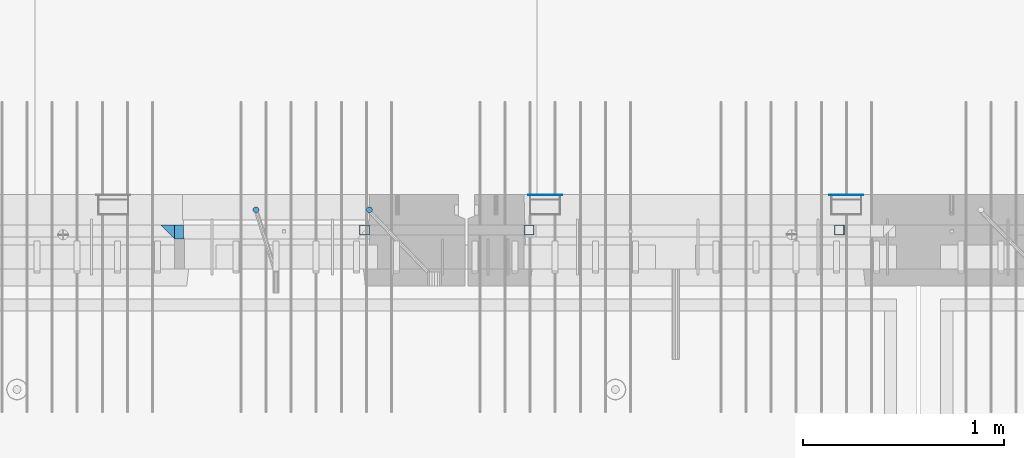
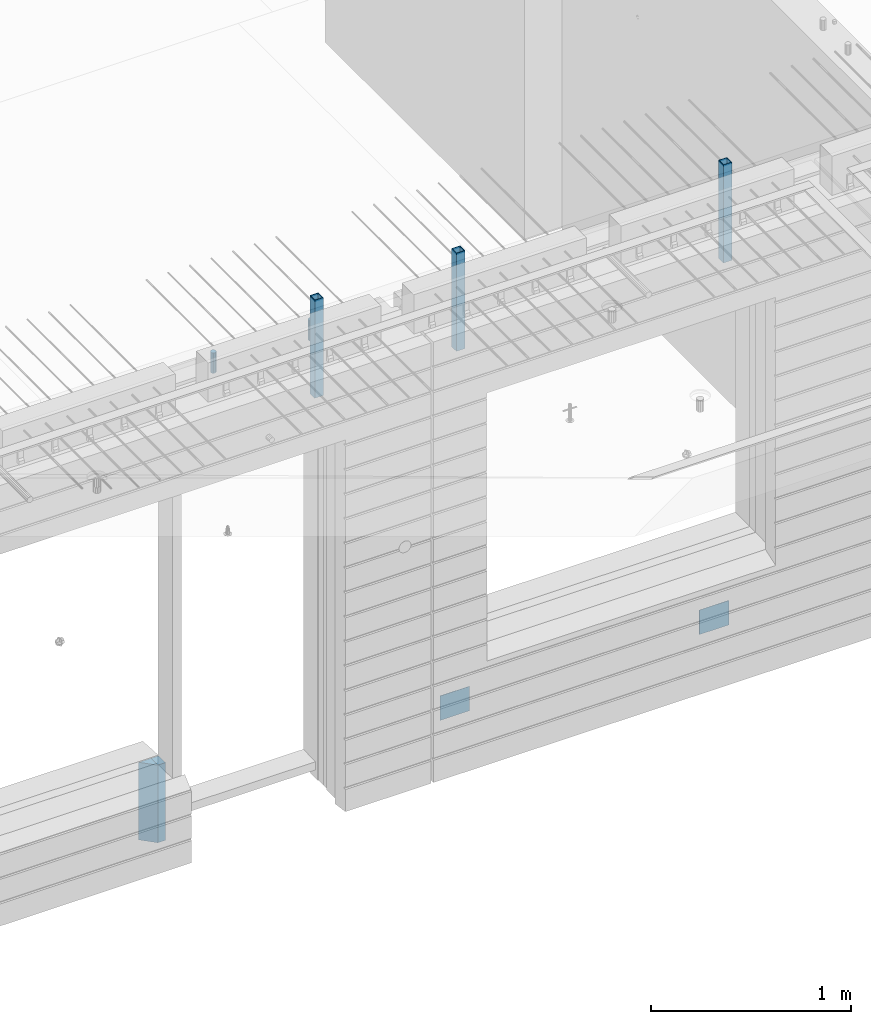
# One storey, part 17 of 349: 9 columns, 7 elements without a shape of their own.
"""IFC2X3 building model written with IfcOpenShell, lengths in millimetres."""

from ifc_helpers import new_model, si_unit, frame, origin_with_axes, place, context, subcontext, project, spatial, faceted_brep, material, type_object, element, aggregate, save


model = new_model("IFC2X3")

# Units and contexts
model_context = context("Model", 3, precision=1e-05, world=origin_with_axes())
body_context = subcontext(model_context, "Body", "Model", "MODEL_VIEW")
ifc_project = project(units=[si_unit("LENGTHUNIT", "METRE", prefix="MILLI"), si_unit("AREAUNIT", "SQUARE_METRE"), si_unit("VOLUMEUNIT", "CUBIC_METRE"), si_unit("MASSUNIT", "GRAM", prefix="KILO"), si_unit("TIMEUNIT", "SECOND"), si_unit("PLANEANGLEUNIT", "RADIAN"), si_unit("SOLIDANGLEUNIT", "STERADIAN"), si_unit("THERMODYNAMICTEMPERATUREUNIT", "DEGREE_CELSIUS"), si_unit("LUMINOUSINTENSITYUNIT", "LUMEN")], contexts=[model_context])

# Site, building, storey
site_placement = place(None, origin_with_axes())
site = spatial("IfcSite", under=ifc_project, at=site_placement, CompositionType="ELEMENT")
building_placement = place(site_placement, origin_with_axes())
building = spatial("IfcBuilding", under=site, at=building_placement, CompositionType="ELEMENT")
storey_placement = place(building_placement, origin_with_axes())
storey = spatial("IfcBuildingStorey", under=building, at=storey_placement, Name="4", CompositionType="ELEMENT", Elevation=0.0)

# Assembly, columns
assembly_1_placement = place(storey_placement, origin_with_axes())
assembly_1 = element("IfcElementAssembly", 1, at=assembly_1_placement, inside=storey, AssemblyPlace="NOTDEFINED", PredefinedType="REINFORCEMENT_UNIT")
ifc_material_1 = material(Name="CONCRETE/C35/45")
column_type_1 = type_object("IfcColumnType", PredefinedType="NOTDEFINED")
column_1_placement = place(assembly_1_placement, frame((24069.9998642727, 7815.0, 90755.0), z_axis=(1.0, 0.0, 0.0), x_axis=(0.0, 0.0, 1.0)))
column_1 = element("IfcColumn", 2, at=column_1_placement, type_object=column_type_1, material=ifc_material_1, Name="SK", context=body_context, shape_type="Brep", body=[
    faceted_brep([(0.0, -35.0, 35.0), (0.0, 35.0, 35.0), (0.0, -35.0, -35.0), (475.0, -35.0, 35.0), (475.0, -35.0, -35.0), (475.0, 35.0, 35.0)], [[[0, 1, 2]], [[3, 0, 2, 4]], [[3, 4, 5]], [[2, 1, 5, 4]], [[0, 3, 5, 1]]]),
])
column_type_2 = type_object("IfcColumnType", PredefinedType="NOTDEFINED")
column_2_placement = place(assembly_1_placement, frame((24129.9998642727, 7815.0, 90755.0), z_axis=(1.0, 0.0, 0.0), x_axis=(0.0, 0.0, 1.0)))
column_2 = element("IfcColumn", 3, at=column_2_placement, type_object=column_type_2, material=ifc_material_1, Name="SK", context=body_context, shape_type="Brep", body=[
    faceted_brep([(0.0, -35.0, -25.0), (0.0, 35.0, -25.0), (475.0, 35.0, -25.0), (475.0, -35.0, -25.0), (0.0, -35.0, 18.8457723764259), (0.0, 35.0, 20.640644171297), (475.0, 35.0, 20.640644171297), (475.0, -35.0, 18.8457723764259)], [[[0, 1, 2, 3]], [[1, 0, 4, 5]], [[2, 1, 5, 6]], [[3, 2, 6, 7]], [[0, 3, 7, 4]], [[6, 5, 4, 7]]]),
])
ifc_material_2 = material()
column_type_3 = type_object("IfcColumnType", Name="D30", PredefinedType="NOTDEFINED")
column_3_placement = place(assembly_1_placement, frame((24510.0000000048, 7924.99999999072, 93407.5), z_axis=(0.0, 1.0, 0.0), x_axis=(0.0, 0.0, 1.0)))
column_3 = element("IfcColumn", 4, at=column_3_placement, type_object=column_type_3, material=ifc_material_2, ObjectType="D30", context=body_context, shape_type="Brep", body=[
    faceted_brep([(0.0, -15.0, 0.0), (0.0, -12.9903810567666, -7.5), (125.0, -12.9903810567666, -7.5), (125.0, -15.0, 0.0), (0.0, -7.5, -12.9903810567666), (125.0, -7.5, -12.9903810567666), (0.0, 0.0, -15.0), (125.0, 0.0, -15.0), (0.0, 7.5, -12.9903810567666), (125.0, 7.5, -12.9903810567666), (0.0, 12.9903810567666, -7.5), (125.0, 12.9903810567666, -7.5), (0.0, 15.0, 0.0), (125.0, 15.0, 0.0), (0.0, 12.9903810567666, 7.5), (125.0, 12.9903810567666, 7.5), (0.0, 7.5, 12.9903810567666), (125.0, 7.5, 12.9903810567666), (0.0, 0.0, 15.0), (125.0, 0.0, 15.0), (0.0, -7.5, 12.9903810567666), (125.0, -7.5, 12.9903810567666), (0.0, -12.9903810567666, 7.5), (125.0, -12.9903810567666, 7.5)], [[[0, 1, 2, 3]], [[1, 4, 5, 2]], [[4, 6, 7, 5]], [[6, 8, 9, 7]], [[8, 10, 11, 9]], [[10, 12, 13, 11]], [[12, 14, 15, 13]], [[14, 16, 17, 15]], [[16, 18, 19, 17]], [[18, 20, 21, 19]], [[20, 22, 23, 21]], [[22, 0, 3, 23]], [[5, 7, 9, 11, 13, 15, 17, 19, 21, 23, 3, 2]], [[22, 20, 18, 16, 14, 12, 10, 8, 6, 4, 1, 0]]]),
])
column_4_placement = place(assembly_1_placement, frame((25074.9926665377, 7925.00000000707, 93407.5), z_axis=(0.0, 1.0, 0.0), x_axis=(0.0, 0.0, 1.0)))
column_4 = element("IfcColumn", 5, at=column_4_placement, type_object=column_type_3, material=ifc_material_2, ObjectType="D30", context=body_context, shape_type="Brep", body=[
    faceted_brep([(0.0, -15.0, 0.0), (0.0, -12.9903810567666, -7.5), (125.0, -12.9903810567666, -7.5), (125.0, -15.0, 0.0), (0.0, -7.5, -12.9903810567666), (125.0, -7.5, -12.9903810567666), (0.0, 0.0, -15.0), (125.0, 0.0, -15.0), (0.0, 7.5, -12.9903810567666), (125.0, 7.5, -12.9903810567666), (0.0, 12.9903810567666, -7.5), (125.0, 12.9903810567666, -7.5), (0.0, 15.0, 0.0), (125.0, 15.0, 0.0), (0.0, 12.9903810567666, 7.5), (125.0, 12.9903810567666, 7.5), (0.0, 7.5, 12.9903810567666), (125.0, 7.5, 12.9903810567666), (0.0, 0.0, 15.0), (125.0, 0.0, 15.0), (0.0, -7.5, 12.9903810567666), (125.0, -7.5, 12.9903810567666), (0.0, -12.9903810567666, 7.5), (125.0, -12.9903810567666, 7.5)], [[[0, 1, 2, 3]], [[1, 4, 5, 2]], [[4, 6, 7, 5]], [[6, 8, 9, 7]], [[8, 10, 11, 9]], [[10, 12, 13, 11]], [[12, 14, 15, 13]], [[14, 16, 17, 15]], [[16, 18, 19, 17]], [[18, 20, 21, 19]], [[20, 22, 23, 21]], [[22, 0, 3, 23]], [[5, 7, 9, 11, 13, 15, 17, 19, 21, 23, 3, 2]], [[22, 20, 18, 16, 14, 12, 10, 8, 6, 4, 1, 0]]]),
])

# Assemblies, columns
assembly_2_placement = place(storey_placement, origin_with_axes())
assembly_2 = element("IfcElementAssembly", 6, at=assembly_2_placement, inside=storey, AssemblyPlace="NOTDEFINED", PredefinedType="REINFORCEMENT_UNIT")
assembly_3_placement = place(assembly_2_placement, origin_with_axes())
assembly_3 = element("IfcElementAssembly", 7, at=assembly_3_placement, Name="Steel Assembly", AssemblyPlace="NOTDEFINED", PredefinedType="NOTDEFINED")
ifc_material_3 = material(Name="Undefined")
column_type_4 = type_object("IfcColumnType", PredefinedType="NOTDEFINED")
column_5_placement = place(assembly_3_placement, frame((25950.0, 7998.99999999844, 90754.9999999985), z_axis=(0.0, 1.0, 0.0), x_axis=(0.0, 0.0, 1.0)))
column_5 = element("IfcColumn", 8, at=column_5_placement, type_object=column_type_4, material=ifc_material_3, Name="SPK2", context=body_context, shape_type="Brep", body=[
    faceted_brep([(0.0, 85.0, -1.0), (0.0, 85.0, 1.0), (150.0, 85.0, 1.0), (150.0, 85.0, -1.0), (0.0, -85.0, 1.0), (150.0, -85.0, 1.0), (0.0, -85.0, -1.0), (150.0, -85.0, -1.0)], [[[0, 1, 2, 3]], [[1, 4, 5, 2]], [[4, 6, 7, 5]], [[6, 0, 3, 7]], [[5, 7, 3, 2]], [[6, 4, 1, 0]]]),
])
aggregate(assembly_3, [column_5])
assembly_4_placement = place(assembly_2_placement, origin_with_axes())
assembly_4 = element("IfcElementAssembly", 9, at=assembly_4_placement, Name="Steel Assembly", AssemblyPlace="NOTDEFINED", PredefinedType="NOTDEFINED")
column_6_placement = place(assembly_4_placement, frame((27450.0, 7998.99999999844, 90754.9999999985), z_axis=(0.0, 1.0, 0.0), x_axis=(0.0, 0.0, 1.0)))
column_6 = element("IfcColumn", 10, at=column_6_placement, type_object=column_type_4, material=ifc_material_3, Name="SPK2", context=body_context, shape_type="Brep", body=[
    faceted_brep([(0.0, 85.0, -1.0), (0.0, 85.0, 1.0), (150.0, 85.0, 1.0), (150.0, 85.0, -1.0), (0.0, -85.0, 1.0), (150.0, -85.0, 1.0), (0.0, -85.0, -1.0), (150.0, -85.0, -1.0)], [[[0, 1, 2, 3]], [[1, 4, 5, 2]], [[4, 6, 7, 5]], [[6, 0, 3, 7]], [[5, 7, 3, 2]], [[6, 4, 1, 0]]]),
])
aggregate(assembly_4, [column_6])

# Assembly
assembly_5_placement = place(assembly_1_placement, origin_with_axes())
assembly_5 = element("IfcElementAssembly", 11, at=assembly_5_placement, Name="Steel Assembly", AssemblyPlace="NOTDEFINED", PredefinedType="RIGID_FRAME")

aggregate(assembly_1, [column_3, column_4, assembly_5, column_1, column_2])

# Column
ifc_material_4 = material(Name="STEEL/S355J2")
column_type_5 = type_object("IfcColumnType", Name="50X50X3", PredefinedType="NOTDEFINED")
column_7_placement = place(assembly_5_placement, frame((25050.0, 7825.0, 93140.0), z_axis=(-1.0, 3.00000001838171e-08, 0.0), x_axis=(0.0, 0.0, 1.0)))
column_7 = element("IfcColumn", 12, at=column_7_placement, type_object=column_type_5, material=ifc_material_4, ObjectType="50X50X3", context=body_context, shape_type="Brep", body=[
    faceted_brep([(0.0, 22.0, -22.0), (0.0, -22.0, -22.0), (600.0, -22.0, -22.0), (600.0, 22.0, -22.0), (0.0, -22.0, 22.0), (600.0, -22.0, 22.0), (0.0, 22.0, 22.0), (600.0, 22.0, 22.0), (0.0, 25.0, -25.0), (0.0, 25.0, 25.0), (600.0, 25.0, 25.0), (600.0, 25.0, -25.0), (0.0, -25.0, 25.0), (600.0, -25.0, 25.0), (0.0, -25.0, -25.0), (600.0, -25.0, -25.0)], [[[0, 1, 2, 3]], [[1, 4, 5, 2]], [[4, 6, 7, 5]], [[6, 0, 3, 7]], [[8, 9, 10, 11]], [[9, 12, 13, 10]], [[12, 14, 15, 13]], [[14, 8, 11, 15]], [[13, 15, 11, 10], [5, 7, 3, 2]], [[14, 12, 9, 8], [6, 4, 1, 0]]]),
])

aggregate(assembly_5, [column_7])

# Assembly, column
assembly_6_placement = place(assembly_2_placement, origin_with_axes())
assembly_6 = element("IfcElementAssembly", 13, at=assembly_6_placement, Name="Steel Assembly", AssemblyPlace="NOTDEFINED", PredefinedType="RIGID_FRAME")
column_8_placement = place(assembly_6_placement, frame((25870.0, 7825.0, 93140.0), z_axis=(-1.0, 3.00000001838171e-08, 0.0), x_axis=(0.0, 0.0, 1.0)))
column_8 = element("IfcColumn", 14, at=column_8_placement, type_object=column_type_5, material=ifc_material_4, ObjectType="50X50X3", context=body_context, shape_type="Brep", body=[
    faceted_brep([(0.0, 22.0, -22.0), (0.0, -22.0, -22.0), (600.0, -22.0, -22.0), (600.0, 22.0, -22.0), (0.0, -22.0, 22.0), (600.0, -22.0, 22.0), (0.0, 22.0, 22.0), (600.0, 22.0, 22.0), (0.0, 25.0, -25.0), (0.0, 25.0, 25.0), (600.0, 25.0, 25.0), (600.0, 25.0, -25.0), (0.0, -25.0, 25.0), (600.0, -25.0, 25.0), (0.0, -25.0, -25.0), (600.0, -25.0, -25.0)], [[[0, 1, 2, 3]], [[1, 4, 5, 2]], [[4, 6, 7, 5]], [[6, 0, 3, 7]], [[8, 9, 10, 11]], [[9, 12, 13, 10]], [[12, 14, 15, 13]], [[14, 8, 11, 15]], [[13, 15, 11, 10], [5, 7, 3, 2]], [[14, 12, 9, 8], [6, 4, 1, 0]]]),
])
aggregate(assembly_6, [column_8])

# Assembly
assembly_7_placement = place(assembly_2_placement, origin_with_axes())
assembly_7 = element("IfcElementAssembly", 15, at=assembly_7_placement, Name="Steel Assembly", AssemblyPlace="NOTDEFINED", PredefinedType="RIGID_FRAME")

aggregate(assembly_2, [assembly_3, assembly_4, assembly_6, assembly_7])

# Column
column_9_placement = place(assembly_7_placement, frame((27415.0, 7825.0, 93140.0), z_axis=(-1.0, 3.00000001838171e-08, 0.0), x_axis=(0.0, 0.0, 1.0)))
column_9 = element("IfcColumn", 16, at=column_9_placement, type_object=column_type_5, material=ifc_material_4, ObjectType="50X50X3", context=body_context, shape_type="Brep", body=[
    faceted_brep([(0.0, 22.0, -22.0), (0.0, -22.0, -22.0), (600.0, -22.0, -22.0), (600.0, 22.0, -22.0), (0.0, -22.0, 22.0), (600.0, -22.0, 22.0), (0.0, 22.0, 22.0), (600.0, 22.0, 22.0), (0.0, 25.0, -25.0), (0.0, 25.0, 25.0), (600.0, 25.0, 25.0), (600.0, 25.0, -25.0), (0.0, -25.0, 25.0), (600.0, -25.0, 25.0), (0.0, -25.0, -25.0), (600.0, -25.0, -25.0)], [[[0, 1, 2, 3]], [[1, 4, 5, 2]], [[4, 6, 7, 5]], [[6, 0, 3, 7]], [[8, 9, 10, 11]], [[9, 12, 13, 10]], [[12, 14, 15, 13]], [[14, 8, 11, 15]], [[13, 15, 11, 10], [5, 7, 3, 2]], [[14, 12, 9, 8], [6, 4, 1, 0]]]),
])

aggregate(assembly_7, [column_9])

save(model, "model.ifc")
